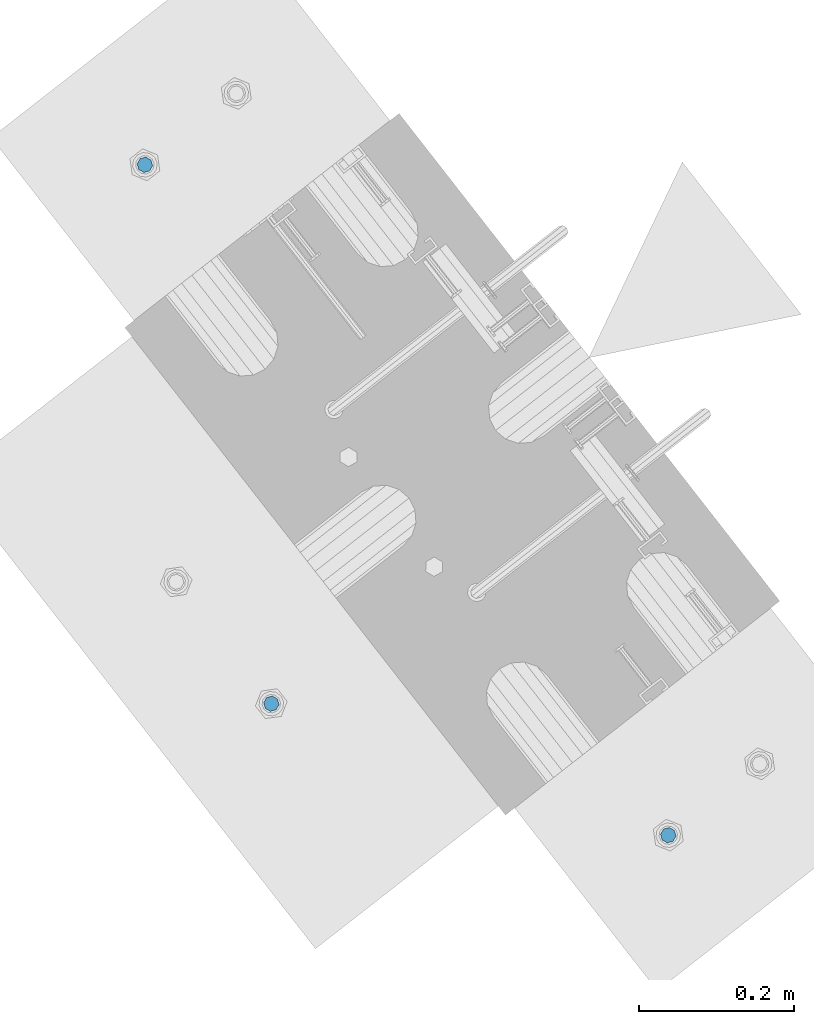
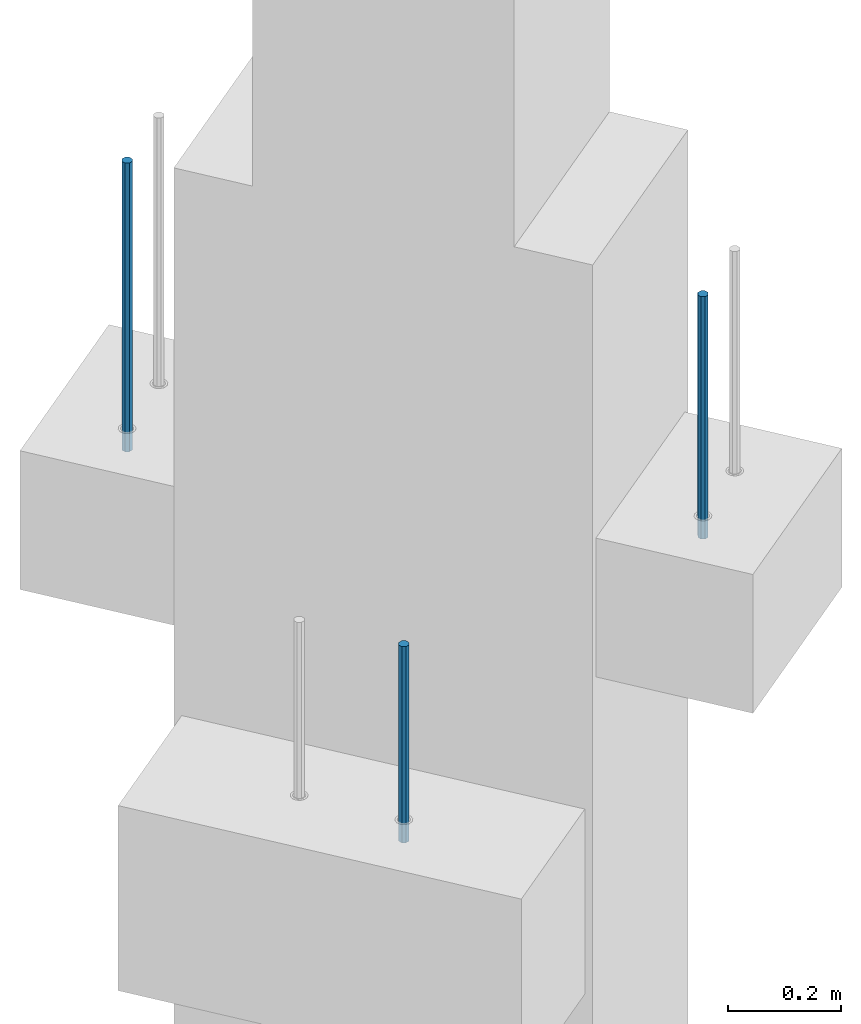
# One storey, part 17 of 42: 3 beams, 1 element without a shape of its own.
"""IFC2X3 building model written with IfcOpenShell, lengths in millimetres."""

from ifc_helpers import new_model, si_unit, frame, origin_with_axes, place, context, subcontext, project, spatial, faceted_brep, material, type_object, element, aggregate, save


model = new_model("IFC2X3")

# Units and contexts
model_context = context("Model", 3, precision=1e-05, world=origin_with_axes())
body_context = subcontext(model_context, "Body", "Model", "MODEL_VIEW")
ifc_project = project(units=[si_unit("LENGTHUNIT", "METRE", prefix="MILLI"), si_unit("AREAUNIT", "SQUARE_METRE"), si_unit("VOLUMEUNIT", "CUBIC_METRE"), si_unit("MASSUNIT", "GRAM", prefix="KILO"), si_unit("TIMEUNIT", "SECOND"), si_unit("PLANEANGLEUNIT", "RADIAN"), si_unit("SOLIDANGLEUNIT", "STERADIAN"), si_unit("THERMODYNAMICTEMPERATUREUNIT", "DEGREE_CELSIUS"), si_unit("LUMINOUSINTENSITYUNIT", "LUMEN")], contexts=[model_context])

# Site, building, storey
site_placement = place(None, frame((171687.4, 84828.52, 14700.0), z_axis=(0.0, 0.0, 1.0), x_axis=(1.0, 0.0, 0.0)))
site = spatial("IfcSite", under=ifc_project, at=site_placement, CompositionType="ELEMENT")
building_placement = place(site_placement, origin_with_axes())
building = spatial("IfcBuilding", under=site, at=building_placement, Name="Undefined", CompositionType="ELEMENT")
storey_placement = place(building_placement, origin_with_axes())
storey = spatial("IfcBuildingStorey", under=building, at=storey_placement, Name="Undefined", CompositionType="ELEMENT", Elevation=0.0)

# Assembly, beams
assembly_placement = place(storey_placement, origin_with_axes())
assembly = element("IfcElementAssembly", 1, at=assembly_placement, inside=storey, AssemblyPlace="NOTDEFINED", PredefinedType="REINFORCEMENT_UNIT")
ifc_material = material(Name="STEEL/S235JR")
beam_type = type_object("IfcBeamType", PredefinedType="NOTDEFINED")
beam_1_placement = place(assembly_placement, frame((17699.2062463749, 265736.658516089, 17750.0), z_axis=(-0.615386219627735, 0.788225729529483, 0.0), x_axis=(0.0, 0.0, -1.0)))
beam_1 = element("IfcBeam", 2, at=beam_1_placement, type_object=beam_type, material=ifc_material, context=body_context, shape_type="Brep", body=[
    faceted_brep([(4.88085788674653e-07, -10.0, -3.86498868465424e-08), (0.0, -7.07106819456385, -7.07106766643119), (624.0, -7.0710680251359, -7.07106751203537), (624.0, -10.0000002132438, 2.99856765195727e-07), (4.97872867461239e-11, -3.88578058618805e-15, -10.0), (624.0, -2.13272869586945e-07, -9.99999970020144), (0.0, 7.07106742914766, -7.0710676664894), (624.0, 7.07106759861927, -7.07106751209358), (4.88085788674653e-07, 10.0, -3.86498868465424e-08), (624.0, 9.99999978675623, 2.99711246043444e-07), (0.0, 7.07106742919132, 7.07106795720756), (624.0, 7.07106759864837, 7.07106811160338), (-4.97872867461239e-11, 0.0, 10.0), (624.0, -2.13214661926031e-07, 10.0000002997695), (0.0, -7.07106819453475, 7.07106795729487), (624.0, -7.0710680251068, 7.07106811166159)], [[[0, 1, 2, 3]], [[1, 4, 5, 2]], [[4, 6, 7, 5]], [[6, 8, 9, 7]], [[8, 10, 11, 9]], [[10, 12, 13, 11]], [[12, 14, 15, 13]], [[14, 0, 3, 15]], [[5, 7, 9, 11, 13, 15, 3, 2]], [[14, 12, 10, 8, 6, 4, 1, 0]]]),
])
beam_2_placement = place(assembly_placement, frame((18376.1312535663, 264869.610342897, 17750.0), z_axis=(0.615386370178831, -0.788225611990706, 0.0), x_axis=(0.0, 0.0, -1.0)))
beam_2 = element("IfcBeam", 3, at=beam_2_placement, type_object=beam_type, material=ifc_material, context=body_context, shape_type="Brep", body=[
    faceted_brep([(4.88085788674653e-07, -10.0, -3.86498868465424e-08), (0.0, -7.07106819456385, -7.07106766643119), (524.0, -7.07106759562157, -7.07106811032281), (524.0, -9.99999978375854, -2.98430677503347e-07), (4.97872867461239e-11, -3.88578058618805e-15, -10.0), (524.0, 2.16212356463075e-07, -10.000000298518), (0.0, 7.07106742914766, -7.0710676664894), (524.0, 7.07106802810449, -7.07106811041012), (4.88085788674653e-07, 10.0, -3.86498868465424e-08), (524.0, 10.0000002162415, -2.98547092825174e-07), (0.0, 7.07106742919132, 7.07106795720756), (524.0, 7.0710680281336, 7.07106751331594), (-4.97872867461239e-11, 0.0, 10.0), (524.0, 2.16299667954445e-07, 9.99999970148201), (0.0, -7.07106819453475, 7.07106795729487), (524.0, -7.07106759559247, 7.07106751340325)], [[[0, 1, 2, 3]], [[1, 4, 5, 2]], [[4, 6, 7, 5]], [[6, 8, 9, 7]], [[8, 10, 11, 9]], [[10, 12, 13, 11]], [[12, 14, 15, 13]], [[14, 0, 3, 15]], [[5, 7, 9, 11, 13, 15, 3, 2]], [[14, 12, 10, 8, 6, 4, 1, 0]]]),
])
beam_3_placement = place(assembly_placement, frame((17862.7397033917, 265039.69595724, 17070.0), z_axis=(-0.788225611989142, -0.615386370180835, 0.0), x_axis=(0.0, 0.0, -1.0)))
beam_3 = element("IfcBeam", 4, at=beam_3_placement, type_object=beam_type, material=ifc_material, context=body_context, shape_type="Brep", body=[
    faceted_brep([(4.88085788674653e-07, -10.0, -3.86498868465424e-08), (0.0, -7.07106819456385, -7.07106766643119), (424.0, -7.07106751357787, -7.07106759684393), (424.0, -9.99999970174395, 2.15019099414349e-07), (4.97872867461239e-11, -3.88578058618805e-15, -10.0), (424.0, 2.98285158351064e-07, -9.9999997849518), (0.0, 7.07106742914766, -7.0710676664894), (424.0, 7.07106811014819, -7.07106759675662), (4.88085788674653e-07, 10.0, -3.86498868465424e-08), (424.0, 10.0000002982561, 2.15106410905719e-07), (0.0, 7.07106742919132, 7.07106795720756), (424.0, 7.07106811011909, 7.07106802696944), (-4.97872867461239e-11, 0.0, 10.0), (424.0, 2.98256054520607e-07, 10.0000002150773), (0.0, -7.07106819453475, 7.07106795729487), (424.0, -7.07106751357787, 7.07106802688213)], [[[0, 1, 2, 3]], [[1, 4, 5, 2]], [[4, 6, 7, 5]], [[6, 8, 9, 7]], [[8, 10, 11, 9]], [[10, 12, 13, 11]], [[12, 14, 15, 13]], [[14, 0, 3, 15]], [[5, 7, 9, 11, 13, 15, 3, 2]], [[14, 12, 10, 8, 6, 4, 1, 0]]]),
])
aggregate(assembly, [beam_1, beam_2, beam_3])

save(model, "model.ifc")
